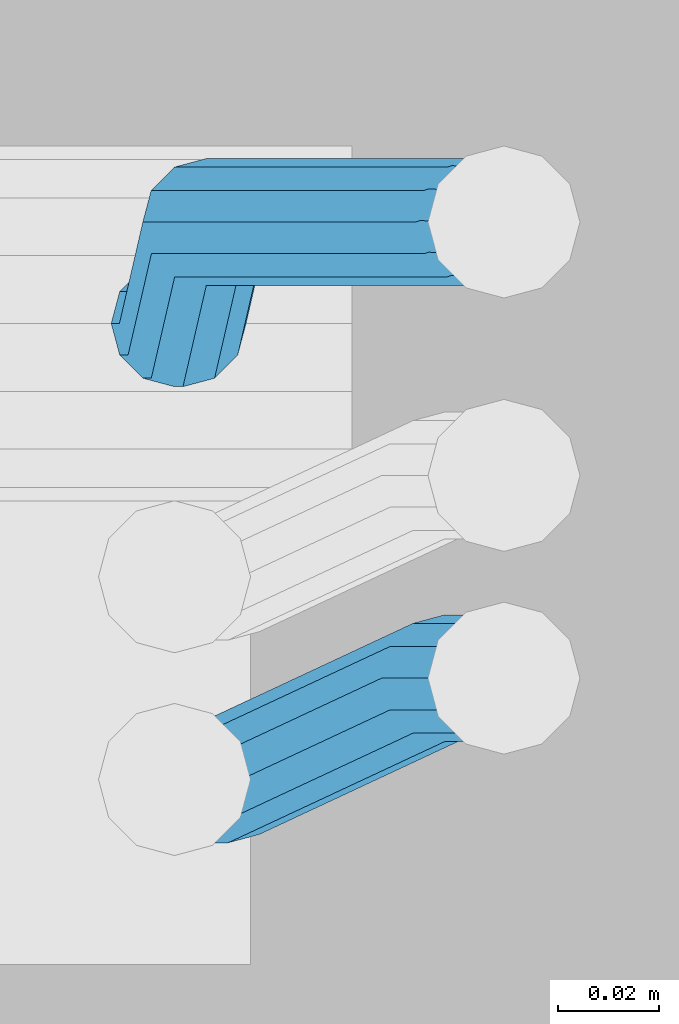
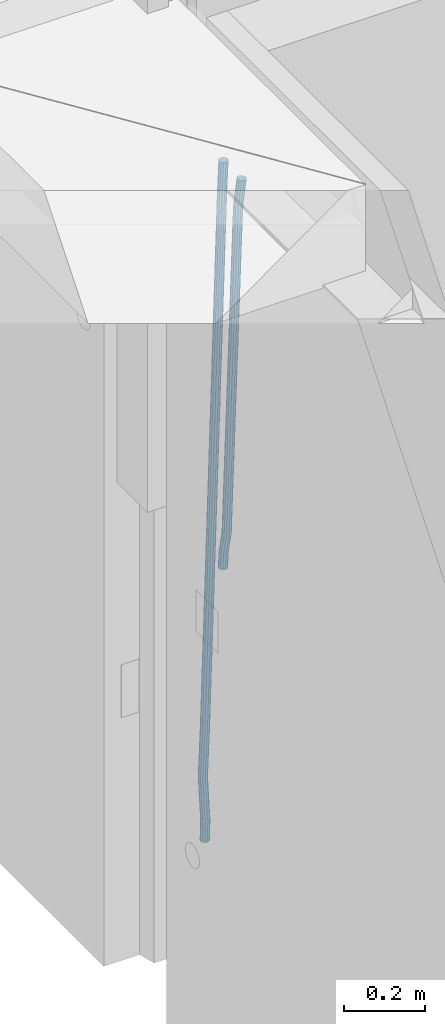
# One storey, part 122 of 349: 2 beams, 1 element without a shape of its own.
"""IFC2X3 building model written with IfcOpenShell, lengths in millimetres."""

from ifc_helpers import new_model, si_unit, frame, origin_with_axes, place, context, subcontext, project, spatial, faceted_brep, material, type_object, element, aggregate, save


model = new_model("IFC2X3")

# Units and contexts
model_context = context("Model", 3, precision=1e-05, world=origin_with_axes())
body_context = subcontext(model_context, "Body", "Model", "MODEL_VIEW")
ifc_project = project(units=[si_unit("LENGTHUNIT", "METRE", prefix="MILLI"), si_unit("AREAUNIT", "SQUARE_METRE"), si_unit("VOLUMEUNIT", "CUBIC_METRE"), si_unit("MASSUNIT", "GRAM", prefix="KILO"), si_unit("TIMEUNIT", "SECOND"), si_unit("PLANEANGLEUNIT", "RADIAN"), si_unit("SOLIDANGLEUNIT", "STERADIAN"), si_unit("THERMODYNAMICTEMPERATUREUNIT", "DEGREE_CELSIUS"), si_unit("LUMINOUSINTENSITYUNIT", "LUMEN")], contexts=[model_context])

# Site, building, storey
site_placement = place(None, origin_with_axes())
site = spatial("IfcSite", under=ifc_project, at=site_placement, CompositionType="ELEMENT")
building_placement = place(site_placement, origin_with_axes())
building = spatial("IfcBuilding", under=site, at=building_placement, CompositionType="ELEMENT")
storey_placement = place(building_placement, origin_with_axes())
storey = spatial("IfcBuildingStorey", under=building, at=storey_placement, Name="4", CompositionType="ELEMENT", Elevation=0.0)

# Assembly, beams
assembly_placement = place(storey_placement, origin_with_axes())
assembly = element("IfcElementAssembly", 1, at=assembly_placement, inside=storey, AssemblyPlace="NOTDEFINED", PredefinedType="REINFORCEMENT_UNIT")
ifc_material = material()
beam_type = type_object("IfcBeamType", Name="D25", PredefinedType="NOTDEFINED")
beam_1_placement = place(assembly_placement, frame((17644.9989431251, 20116.4982803956, 92267.5035525011), z_axis=(0.0, 1.0, 0.0), x_axis=(0.0467115440025518, 0.0, 0.998908420055061)))
beam_1 = element("IfcBeam", 2, at=beam_1_placement, type_object=beam_type, material=ifc_material, Name="JM25", ObjectType="D25", context=body_context, shape_type="Brep", body=[
    faceted_brep([(-7.41420080885291e-08, -12.5, -3.63797880709171e-12), (-6.42030499875546e-08, -10.8253175473074, -6.25000000000364), (48.7743672639481, -10.8253174221936, -6.25), (48.7743672682554, -12.4999998748863, 0.0), (-3.70782800018787e-08, -6.25000000000364, -10.8253175473074), (48.7743672522192, -6.24999987488263, -10.8253175473037), (-1.45519152283669e-11, -3.63797880709171e-12, -12.5), (48.7743672361976, 1.25113729154691e-07, -12.5), (3.70637280866504e-08, 6.25, -10.8253175473074), (48.7743672201614, 6.25000012511737, -10.8253175473037), (6.42030499875546e-08, 10.8253175473001, -6.25000000000364), (48.774367208418, 10.8253176724174, -6.25), (7.41420080885291e-08, 12.4999999999927, 0.0), (48.7743672041252, 12.5000001251174, 0.0), (6.42176019027829e-08, 10.8253175473001, 6.24999999999636), (48.774367208418, 10.8253176724174, 6.25), (3.70928319171071e-08, 6.24999999999636, 10.8253175473037), (48.7743672201614, 6.25000012511737, 10.8253175473037), (1.45519152283669e-11, -3.63797880709171e-12, 12.4999999999964), (48.7743672361976, 1.25113729154691e-07, 12.5), (-3.7049176171422e-08, -6.25000000000364, 10.8253175473001), (48.7743672522192, -6.24999987488263, 10.8253175473037), (-6.41884980723262e-08, -10.8253175473074, 6.25), (48.7743672639481, -10.8253174221936, 6.25), (50.6284132863948, -10.8253174174351, -6.25), (50.7256294211547, -12.4999998698804, 0.0), (50.362813866901, -6.2499998708081, -10.8253175473037), (49.9999983126327, 1.28262399812229e-07, -12.5), (49.6371827583935, 6.25000012732926, -10.8253175473037), (49.3715833388851, 10.8253176739527, -6.25), (49.2743672041252, 12.5000001264016, 0.0), (49.3715833388851, 10.8253176739527, 6.25), (49.6371827583935, 6.25000012732926, 10.8253175473037), (49.9999983126327, 1.28262399812229e-07, 12.5), (50.362813866901, -6.2499998708081, 10.8253175473037), (50.6284132863948, -10.8253174174351, 6.25), (52.4700055286376, -10.6107838149001, -6.25), (52.6637847850943, -12.2742172873113, 0.0), (51.9405907545442, -6.0661990532717, -10.8253175473037), (51.2173967239651, 0.141819180764287, -12.5), (50.494202693415, 6.34983741480755, -10.8253175473037), (49.9647879192926, 10.8944221764359, -6.25), (49.7710086628358, 12.5578556488472, 0.0), (49.9647879192926, 10.8944221764359, 6.25), (50.494202693415, 6.34983741480755, 10.8253175473037), (51.2173967239651, 0.141819180764287, 12.5), (51.9405907545442, -6.0661990532717, 10.8253175473037), (52.4700055286376, -10.6107838149037, 6.25), (100.1682419055, -5.05424733003747, -6.25), (100.362021161956, -6.71768080244692, 0.0), (99.6388271314063, -0.509662568409112, -10.8253175473037), (98.9156331008271, 5.69835566563052, -12.5), (98.192439070277, 11.9063738996665, -10.8253175473037), (97.6630242961546, 16.4509586612985, -6.25), (97.4692450396979, 18.1143921337098, 0.0), (97.6630242961546, 16.4509586612985, 6.25), (98.192439070277, 11.9063738996665, 10.8253175473037), (98.9156331008271, 5.69835566563052, 12.5), (99.6388271314063, -0.509662568409112, 10.8253175473037), (100.1682419055, -5.05424733003747, 6.25), (100.829389846811, -4.97722786481609, -6.25), (100.858662620667, -6.65982528000313, 0.0), (100.613505361369, -0.39611884945225, -10.8253175473037), (100.268855237926, 5.8559973049887, -12.5), (99.8877881987282, 12.1038711239344, -10.8253175473037), (99.5724108491268, 16.6733898631865, -6.25), (99.4072282953421, 18.3401546667665, 0.0), (99.4365010692127, 16.6575572515831, 6.25), (99.6523855546402, 12.0764482362174, 10.8253175473037), (99.9970356780832, 5.82433208178009, 12.5), (100.37810271731, -0.423541737165579, 10.8253175473037), (100.693480066882, -4.99306047642312, 6.25), (101.494850382805, -4.9772278650471, -6.23547852116099), (101.358543616545, -6.65982528017412, 0.0109082521194068), (101.594541309358, -0.396118849792401, -10.8039096771354), (101.63090429295, 5.85599730451395, -12.4702777768798), (101.594195901474, 12.1038711233377, -10.7880808337759), (101.49425211882, 16.6733898625134, -6.2080621602363), (101.357852800793, 18.340154666088, 0.0425659388420172), (101.221546034547, 16.6575572509591, 6.28895271212241), (101.121855107995, 12.0764482357044, 10.8573838680968), (101.085492124403, 5.82433208139992, 12.5237519678412), (101.122200515863, -0.423541737425694, 10.8415550247373), (101.222144298532, -4.99306047660866, 6.26153635119772), (1016.15234243186, -4.97722818425427, 13.7239010304511), (1016.01603566563, -6.65982559938311, 19.9702878037351), (1016.25203335841, -0.396119168995938, 9.15546987447669), (1016.28839634202, 5.85599698530859, 7.48910177473226), (1016.25168795056, 12.1038708041378, 9.17129871783618), (1016.15174416787, 16.6733895433135, 13.7513173913758), (1016.01534484986, 18.3401543468826, 20.0019454904541), (1015.8790380836, 16.6575569317556, 26.2483322637381), (1015.77934715705, 12.0764479165045, 30.8167634197125), (1015.74298417347, 5.82433176219456, 32.4831315194569), (1015.77969256493, -0.423542056632868, 30.8009345763494), (1015.8796363476, -4.99306079580856, 26.2209159028134), (1016.72024271244, -4.97722818445254, 13.7362935788587), (1016.65208128402, -6.65982559960139, 19.984167399125), (1016.77009392806, -0.396119169179656, 9.16677483576495), (1016.7882773379, 5.85599698513579, 7.50001002685531), (1016.76992071191, 12.1038708039559, 9.18260743664359), (1016.71994269331, 16.6733895431171, 13.7637164479929), (1016.65173485172, 18.3401543466607, 20.015832600875), (1016.58357342328, 16.65755693151, 26.2637064211413), (1016.53372220766, 12.0764479162353, 30.833225164235), (1016.51553879784, 5.82433176192717, 32.4999899731447), (1016.53389542381, -0.423542056894803, 30.8173925633564), (1016.58387344243, -4.99306079605594, 26.2362835520071), (1017.28827819017, -4.97722813975997, 13.7362935788587), (1017.28827832255, -6.6598255495519, 19.984167399125), (1017.28827782976, -0.396119128414284, 9.16677483576495), (1017.28827733788, 5.85599702447144, 7.50001002685531), (1017.28827684635, 12.103870844734, 9.18260743664359), (1017.28827648686, 16.6733895878278, 13.7637164479929), (1017.28827635571, 18.3401543967448, 20.015832600875), (1017.28827648809, 16.657556986951, 26.2637064211413), (1017.2882768485, 12.0764479756035, 30.833225164235), (1017.28827734038, 5.8243318227178, 32.4999899731447), (1017.28827783192, -0.423541997544817, 30.8173925633564), (1017.28827819142, -4.99306074063679, 26.2362835520071), (1065.6667756622, -4.97722433367016, 13.7362935788587), (1065.66677579457, -6.65982174345845, 19.984167399125), (1065.6667753018, -0.3961153223172, 9.16677483576495), (1065.66677480991, 5.85600083056488, 7.50001002685531), (1065.66677431838, 12.1038746508275, 9.18260743664359), (1065.66677395887, 16.6733933939249, 13.7637164479929), (1065.66677382775, 18.3401582028346, 20.015832600875), (1065.66677396011, 16.6575607930445, 26.2637064211413), (1065.66677432053, 12.0764517816933, 30.833225164235), (1065.6667748124, 5.82433562881488, 32.4999899731447), (1065.66677530395, -0.423538191451371, 30.8173925633564), (1065.66677566344, -4.99305693454517, 26.2362835520071), (1067.07165110651, -4.97722422314291, 13.7362935788587), (1067.13694763639, -6.65982162779255, 19.984167399125), (1066.89387208481, -0.396115225779795, 9.16677483576495), (1066.6512463166, 5.85600090801745, 7.50001002685531), (1066.40878518049, 12.1038747092061, 9.18260743664359), (1066.23145594214, 16.6733934383519, 13.7637164479929), (1066.16677382775, 18.340158242172, 20.015832600875), (1066.23207035761, 16.6575608375188, 26.2637064211413), (1066.40984937931, 12.0764518401556, 30.833225164235), (1066.65247514757, 5.82433570636204, 32.4999899731447), (1066.89493628364, -0.423538094826654, 30.8173925633564), (1067.07226552199, -4.99305682397062, 26.2362835520071), (1068.47230333716, -4.86837412698696, 13.736334784764), (1068.60269804588, -6.54588751704068, 19.9842150143704), (1068.11728165975, -0.301059828409052, 9.16679859123906), (1067.63276078545, 5.93224720081525, 7.50000996663584), (1067.14856769117, 12.161337376032, 9.18258357686864), (1066.79444152558, 16.7171310152116, 13.7636751818718), (1066.66527010873, 18.3789068918468, 20.0157849856296), (1066.79566481744, 16.7013935018003, 26.263665215236), (1067.15068649485, 12.134079203217, 30.8332014087609), (1067.63520736917, 5.90077217399266, 32.4999900333642), (1068.11940046342, -0.328318001224034, 30.8174164231314), (1068.47352662902, -4.88411164040008, 26.2363248181282), (1142.62319484423, 0.89544508106701, 13.736334784764), (1142.75358955294, -0.782068308983071, 19.9842150143704), (1142.26817316683, 5.4627593796431, 9.16679859123906), (1141.78365229251, 11.6960664088729, 7.50000996663584), (1141.29945919824, 17.9251565840896, 9.18258357686864), (1140.94533303265, 22.4809502232638, 13.7636751818718), (1140.81616161579, 24.1427260999008, 20.0157849856296), (1140.94655632452, 22.4652127098525, 26.263665215236), (1141.30157800192, 17.8978984112746, 30.8332014087609), (1141.78609887623, 11.6645913820466, 32.4999900333642), (1142.27029197049, 5.43550120682994, 30.8174164231314), (1142.6244181361, 0.879707567652076, 26.2363248181282)], [[[0, 1, 2, 3]], [[1, 4, 5, 2]], [[4, 6, 7, 5]], [[6, 8, 9, 7]], [[8, 10, 11, 9]], [[10, 12, 13, 11]], [[12, 14, 15, 13]], [[14, 16, 17, 15]], [[16, 18, 19, 17]], [[18, 20, 21, 19]], [[20, 22, 23, 21]], [[22, 0, 3, 23]], [[22, 20, 18, 16, 14, 12, 10, 8, 6, 4, 1, 0]], [[3, 2, 24, 25]], [[2, 5, 26, 24]], [[5, 7, 27, 26]], [[7, 9, 28, 27]], [[9, 11, 29, 28]], [[11, 13, 30, 29]], [[13, 15, 31, 30]], [[15, 17, 32, 31]], [[17, 19, 33, 32]], [[19, 21, 34, 33]], [[21, 23, 35, 34]], [[23, 3, 25, 35]], [[25, 24, 36, 37]], [[24, 26, 38, 36]], [[26, 27, 39, 38]], [[27, 28, 40, 39]], [[28, 29, 41, 40]], [[29, 30, 42, 41]], [[30, 31, 43, 42]], [[31, 32, 44, 43]], [[32, 33, 45, 44]], [[33, 34, 46, 45]], [[34, 35, 47, 46]], [[35, 25, 37, 47]], [[37, 36, 48, 49]], [[36, 38, 50, 48]], [[38, 39, 51, 50]], [[39, 40, 52, 51]], [[40, 41, 53, 52]], [[41, 42, 54, 53]], [[42, 43, 55, 54]], [[43, 44, 56, 55]], [[44, 45, 57, 56]], [[45, 46, 58, 57]], [[46, 47, 59, 58]], [[47, 37, 49, 59]], [[49, 48, 60, 61]], [[48, 50, 62, 60]], [[50, 51, 63, 62]], [[51, 52, 64, 63]], [[52, 53, 65, 64]], [[53, 54, 66, 65]], [[54, 55, 67, 66]], [[55, 56, 68, 67]], [[56, 57, 69, 68]], [[57, 58, 70, 69]], [[58, 59, 71, 70]], [[59, 49, 61, 71]], [[61, 60, 72, 73]], [[60, 62, 74, 72]], [[62, 63, 75, 74]], [[63, 64, 76, 75]], [[64, 65, 77, 76]], [[65, 66, 78, 77]], [[66, 67, 79, 78]], [[67, 68, 80, 79]], [[68, 69, 81, 80]], [[69, 70, 82, 81]], [[70, 71, 83, 82]], [[71, 61, 73, 83]], [[73, 72, 84, 85]], [[72, 74, 86, 84]], [[74, 75, 87, 86]], [[75, 76, 88, 87]], [[76, 77, 89, 88]], [[77, 78, 90, 89]], [[78, 79, 91, 90]], [[79, 80, 92, 91]], [[80, 81, 93, 92]], [[81, 82, 94, 93]], [[82, 83, 95, 94]], [[83, 73, 85, 95]], [[85, 84, 96, 97]], [[84, 86, 98, 96]], [[86, 87, 99, 98]], [[87, 88, 100, 99]], [[88, 89, 101, 100]], [[89, 90, 102, 101]], [[90, 91, 103, 102]], [[91, 92, 104, 103]], [[92, 93, 105, 104]], [[93, 94, 106, 105]], [[94, 95, 107, 106]], [[95, 85, 97, 107]], [[97, 96, 108, 109]], [[96, 98, 110, 108]], [[98, 99, 111, 110]], [[99, 100, 112, 111]], [[100, 101, 113, 112]], [[101, 102, 114, 113]], [[102, 103, 115, 114]], [[103, 104, 116, 115]], [[104, 105, 117, 116]], [[105, 106, 118, 117]], [[106, 107, 119, 118]], [[107, 97, 109, 119]], [[109, 108, 120, 121]], [[108, 110, 122, 120]], [[110, 111, 123, 122]], [[111, 112, 124, 123]], [[112, 113, 125, 124]], [[113, 114, 126, 125]], [[114, 115, 127, 126]], [[115, 116, 128, 127]], [[116, 117, 129, 128]], [[117, 118, 130, 129]], [[118, 119, 131, 130]], [[119, 109, 121, 131]], [[121, 120, 132, 133]], [[120, 122, 134, 132]], [[122, 123, 135, 134]], [[123, 124, 136, 135]], [[124, 125, 137, 136]], [[125, 126, 138, 137]], [[126, 127, 139, 138]], [[127, 128, 140, 139]], [[128, 129, 141, 140]], [[129, 130, 142, 141]], [[130, 131, 143, 142]], [[131, 121, 133, 143]], [[133, 132, 144, 145]], [[132, 134, 146, 144]], [[134, 135, 147, 146]], [[135, 136, 148, 147]], [[136, 137, 149, 148]], [[137, 138, 150, 149]], [[138, 139, 151, 150]], [[139, 140, 152, 151]], [[140, 141, 153, 152]], [[141, 142, 154, 153]], [[142, 143, 155, 154]], [[143, 133, 145, 155]], [[145, 144, 156, 157]], [[144, 146, 158, 156]], [[146, 147, 159, 158]], [[147, 148, 160, 159]], [[148, 149, 161, 160]], [[149, 150, 162, 161]], [[150, 151, 163, 162]], [[151, 152, 164, 163]], [[152, 153, 165, 164]], [[153, 154, 166, 165]], [[154, 155, 167, 166]], [[155, 145, 157, 167]], [[158, 159, 160, 161, 162, 163, 164, 165, 166, 167, 157, 156]]]),
])
beam_2_placement = place(assembly_placement, frame((17645.0, 20206.4982799665, 91390.0), z_axis=(0.999642804629538, 0.000205762999925497, -0.0267249099901003), x_axis=(0.0267249109941254, -4.30000210532798e-08, 0.999642825779465)))
beam_2 = element("IfcBeam", 3, at=beam_2_placement, type_object=beam_type, material=ifc_material, Name="JM25", ObjectType="D25", context=body_context, shape_type="Brep", body=[
    faceted_brep([(-7.41420080885291e-08, -12.5, -3.63797880709171e-12), (-6.42030499875546e-08, -10.8253175473074, -6.25000000000364), (59.4220778053423, -10.8253175324608, -6.25000005319089), (59.4220778086747, -12.4999999851534, -5.3194526117295e-08), (-3.70782800018787e-08, -6.25000000000364, -10.8253175473074), (59.4220778020681, -6.24999998515341, -10.8253176004946), (-1.45519152283669e-11, -3.63797880709171e-12, -12.5), (59.4220777997252, 1.48465915117413e-08, -12.5000000531927), (3.70637280866504e-08, 6.25, -10.8253175473074), (59.422077798954, 6.25000001485023, -10.8253176004982), (6.42030499875546e-08, 10.8253175473001, -6.25000000000364), (59.4220777999435, 10.8253175621539, -6.25000005319089), (7.41420080885291e-08, 12.4999999999927, 0.0), (59.4220778024173, 12.5000000148466, -5.31908881384879e-08), (6.42176019027829e-08, 10.8253175473001, 6.24999999999636), (59.4220778057497, 10.8253175621576, 6.24999994680911), (3.70928319171071e-08, 6.24999999999636, 10.8253175473037), (59.4220778090239, 6.25000001485023, 10.8253174941128), (1.45519152283669e-11, -3.63797880709171e-12, 12.4999999999964), (59.4220778113668, 1.48465915117413e-08, 12.4999999468128), (-3.7049176171422e-08, -6.25000000000364, 10.8253175473001), (59.4220778121526, -6.24999998515705, 10.8253174941183), (-6.41884980723262e-08, -10.8253175473074, 6.25), (59.422077811163, -10.8253175324571, 6.24999994680547), (60.1059015733626, -10.8253175322861, -6.25000005380571), (59.9220778086747, -12.4999999850261, -5.36383595317602e-08), (60.5270973313018, -6.24999998487692, -10.8253176014878), (61.0728060192778, 1.52613210957497e-08, -12.5000000546715), (61.5968054350378, 6.25000001539229, -10.8253176024446), (61.9586903583258, 10.825317562787, -6.25000005546281), (62.0614940161613, 12.5000000155051, -5.55555743630975e-08), (61.8776702514588, 10.8253175627651, 6.24999994460995), (61.4564744935342, 6.25000001535955, 10.8253174922938), (60.9107658055436, 1.52213033288717e-08, 12.4999999454776), (60.3867663897981, -6.2499999849133, 10.8253174932506), (60.0248814664956, -10.825317532308, 6.24999994626887), (60.7797257564671, -10.9415004936782, -6.24120031120765), (60.4147662867617, -12.5849509379113, 0.00643416450657242), (61.6159581115353, -6.43774490879878, -10.8110977280703), (62.6993955677171, -0.280461855141766, -12.4787577637399), (63.739731933616, 5.88050964549984, -10.7973322583985), (64.4582099200925, 10.3943422549237, -6.21735781835014), (64.6623139309086, 12.0515581706859, 0.03396510384664), (64.2973544612178, 10.4081077264564, 6.28159957956086), (63.461122106135, 5.90435214157333, 10.8514969964235), (62.3776846499532, -0.252930912083684, 12.5191570320894), (61.3373482840689, -6.41390241272165, 10.8377315267553), (60.6188702975924, -10.9277350221564, 6.25775708670699), (173.678050556482, -30.407797550004, -4.76681541592006), (173.313091086762, -32.0512479942336, 1.4808190597978), (174.514282911536, -25.9040419651246, -9.33671283278272), (175.597720367718, -19.7467589114676, -11.0043728684504), (176.638056733602, -13.585787410826, -9.32294736311087), (177.356534720093, -9.0719548013949, -4.74297292306073), (177.560638730924, -7.41473888563996, 1.50834999913423), (177.195679261218, -9.05818932986585, 7.75598447485027), (176.35944690615, -13.5619449147489, 12.3258818917166), (175.276009449968, -19.7192279684059, 13.9935419273806), (174.235673084069, -25.8801994690475, 12.3121164220465), (173.517195097593, -30.3940320784823, 7.73214198199094), (176.138237106381, -30.8319909317906, -4.73468684452382), (175.913853754129, -32.499679968274, 1.51478347157899), (176.589132212815, -26.2617942428296, -9.30961653639861), (177.145722093832, -20.0136704134529, -10.98415688768), (177.658868940271, -13.7617991779516, -9.30961616354944), (177.991075469021, -9.18136438506554, -4.73468619872801), (178.053327209011, -7.49968983852159, 1.5147842172828), (177.828943856759, -9.16737887500858, 7.76425453338925), (177.37804875031, -13.7375755639696, 12.3391842252604), (176.821458869294, -19.9856993933463, 14.0137245765418), (176.308312022869, -26.237570628844, 12.3391838524112), (175.976105494119, -30.8180054217337, 7.76425388758798), (178.634722048839, -30.8318743800774, -4.70223538057326), (178.552989161486, -32.4996730848652, 1.54907076560085), (178.694593853957, -26.2615981169292, -9.28219734144659), (178.71656197503, -20.0134461293128, -10.9636180082289), (178.694740071747, -13.7616056964944, -9.29596207112627), (178.634975305482, -9.18125241366579, -4.72607659172718), (178.553281597095, -7.49968824400275, 1.52154130624513), (178.471548709742, -9.16748694879061, 7.7728474524265), (178.411676904623, -13.7377632119424, 12.3528094132944), (178.389708783536, -19.9859151995588, 14.0342300800785), (178.411530686833, -26.23775563237, 12.3665741429741), (178.471295453099, -30.8181089152022, 7.79668866358043), (319.488626215083, -30.8314939674237, -2.86053540860667), (319.406893327759, -32.499292672208, 3.39077073757289), (319.548498020216, -26.261217704272, -7.44049736947818), (319.570466141289, -20.0130657166519, -9.12191803626411), (319.548644237992, -13.7612252838408, -7.45426209915786), (319.488879471741, -9.18087200101581, -2.88437661976423), (319.407185763353, -7.4993078313455, 3.36324127821172), (319.325452876015, -9.167106536137, 9.61454742438946), (319.265581070882, -13.7373827992851, 14.1945093852592), (319.243612949809, -19.9855347868979, 15.8759300520433), (319.265434853078, -26.2373752197163, 14.2082741149388), (319.325199619343, -30.8177285025449, 9.63838863554338), (320.017443228702, -30.8314925392151, -2.85362099409576), (319.964532372032, -32.4992911661575, 3.39806200733256), (320.056202037245, -26.2612163330814, -7.43385901266629), (320.070423406214, -20.013064366387, -9.11538097016819), (320.056296731302, -13.7612239127957, -7.44762441603234), (320.01760724363, -9.18087057304729, -2.87746337211138), (319.964721760145, -7.4993063255788, 3.37053120060227), (319.91181090349, -9.16710495252482, 9.62221420203059), (319.873052094961, -13.7373811586476, 14.2024522205975), (319.858830725978, -19.9855331253457, 15.8839741781048), (319.87295740089, -26.2373735789442, 14.2162176239653), (319.911646888577, -30.8177269186926, 9.64605658004257), (320.546301518712, -30.8314921215424, -2.85158332608989), (320.522214942423, -32.4992907257256, 3.40021073403295), (320.563945682734, -26.2612159320888, -7.431902698474), (320.570419694937, -20.0130639715098, -9.1134545062032), (320.563988849026, -13.7612235118395, -7.44566830037184), (320.546376284925, -9.1808701554437, -2.87542604797454), (320.522301275021, -7.49930588522329, 3.37267953023547), (320.498214698731, -9.16710448940648, 9.62447359036014), (320.480570534695, -13.7373806788601, 14.2047929627461), (320.474096522506, -19.9855326394354, 15.8863447704753), (320.480527368418, -26.2373730991094, 14.2185585646439), (320.498139932504, -30.8177264555052, 9.64831631225024), (1894.35323904471, -30.8302491939103, 3.21222639639745), (1894.32915246842, -32.4980477980898, 9.46402045652394), (1894.37088320871, -26.2599730044531, -1.36809297598302), (1894.37735722095, -20.0118210438777, -3.04964478371585), (1894.37092637502, -13.7599805842037, -1.38185857788449), (1894.35331381093, -9.1796272278043, 3.18838367451281), (1894.32923880102, -7.4980629575839, 9.43648925272464), (1894.30515222471, -9.16586156176709, 15.6882833128511), (1894.2875080607, -13.7361377512207, 20.2686026852371), (1894.28103404849, -19.9842897117996, 21.9501544929644), (1894.2874648944, -26.2361301714736, 20.2823682871331), (1894.30507745848, -30.8164835278658, 15.7121260347358), (1894.91223858956, -30.8302487524343, 3.21438019734705), (1894.84772318714, -32.4980473885444, 9.46601848696628), (1894.98133310449, -26.2599725223481, -1.36574093906893), (1895.03649291246, -20.0118205233157, -3.04710516254454), (1895.06293798747, -13.7599800376811, -1.37919228721876), (1895.05358239301, -9.17962667476604, 3.19108177892304), (1895.01093295308, -7.49806241920669, 9.43911579066662), (1894.94641755069, -9.16586105532406, 15.6907540802767), (1894.87732303573, -13.7361372854102, 20.2708752166945), (1894.82216322777, -19.984289284439, 21.9522394401702), (1894.79571815276, -26.2361297700772, 20.284326564848), (1894.80507374721, -30.8164831329887, 15.7140524987026), (1895.47114527243, -30.837537004496, 3.22181869265842), (1895.36620776, -32.5048085284143, 9.47291900396158), (1895.59168159126, -26.267931585553, -1.35761780421126), (1895.69551910722, -20.0204143533228, -3.03833417552232), (1895.75483464175, -13.7690025048832, -1.36998382688762), (1895.75373464527, -9.18875679657504, 3.20040011310266), (1895.69251386097, -7.50695036707475, 9.44818695861068), (1895.58757634854, -9.17422189099307, 15.699287269912), (1895.4670400297, -13.7438273099324, 20.2787237667835), (1895.36320251375, -19.9913445421626, 21.9594401380946), (1895.30388697921, -26.2427563905985, 20.2910897894599), (1895.30498697569, -30.823002098914, 15.720705849466), (1917.25744196717, -31.1216345590001, 3.51177275974987), (1917.15250445475, -32.788906082922, 9.7628730710494), (1917.37797828601, -26.5520291400608, -1.0676637371198), (1917.48181580196, -20.3045119078306, -2.7483801084345), (1917.5411313365, -14.0531000593946, -1.08002975979252), (1917.54003134, -9.47285435107915, 3.49035418019412), (1917.47881055571, -7.7910479215825, 9.73814102570577), (1917.37387304328, -9.45831944550082, 15.9892413370071), (1917.25333672446, -14.0279248644365, 20.5686778338786), (1917.14949920849, -20.2754420966667, 22.2493942051933), (1917.09018367396, -26.5268539451099, 20.5810438565477), (1917.09128367042, -31.1070996534218, 16.0106599165647), (1917.94316974688, -31.1305765828838, 3.52089911846269), (1917.85264237775, -32.7980360178735, 9.77219121452072), (1918.02633208608, -26.5604837999635, -1.05903478912296), (1918.0798461137, -20.3123103396429, -2.7404209163069), (1918.08937278928, -14.0602492347753, -1.07273320814602), (1918.05235944779, -9.47953520944429, 3.49717276072806), (1917.9787237842, -7.79756688750422, 9.74479437647096), (1917.88819641506, -9.46502632249758, 15.9960864725308), (1917.80503407588, -14.0351191054142, 20.5760203801128), (1917.75152004823, -20.2832925657385, 22.257406507304), (1917.74199337266, -26.5353536706025, 20.5897187991395), (1917.77900671415, -31.1160676959298, 16.0198128302654), (1918.62895550129, -31.1285475281402, 3.52982218347461), (1918.55283939735, -32.795947999115, 9.78130547352521), (1918.67474087057, -26.5585779185749, -1.05060823136955), (1918.67792735249, -20.3105588367471, -2.73266314035027), (1918.63766113177, -14.0586419499232, -1.06563728897891), (1918.56473150974, -9.47802333907384, 3.50379109209644), (1918.47867991975, -7.79607606181162, 9.75124735830832), (1918.40256381579, -9.46347653279008, 16.0027306483644), (1918.35677844651, -14.0334461423481, 20.5831610632049), (1918.35359196461, -20.2814652241759, 22.2652159721838), (1918.39385818531, -26.5333821109998, 20.5981901208143), (1918.46678780734, -31.1140007218564, 16.0287617397316), (2018.62971518922, -30.8303462840922, 4.82693655916046), (2018.5535990853, -32.4977467550671, 11.0784198492183), (2018.67550055851, -26.2603766745233, 0.246506144323575), (2018.67868704045, -20.0123575926991, -1.43554876465714), (2018.63842081973, -13.7604407058789, 0.231477086710584), (2018.5654911977, -9.17982209502588, 4.80090546778956), (2018.47943960771, -7.49787481776366, 11.0483617339996), (2018.40332350375, -9.16527528874212, 17.2998450240593), (2018.35753813446, -13.7352448983038, 21.880275438898), (2018.35435165254, -19.9832639801316, 23.5623303478787), (2018.39461787326, -26.2351808669555, 21.8953044965092), (2018.46754749528, -30.8157994778048, 17.3258761154248)], [[[0, 1, 2, 3]], [[1, 4, 5, 2]], [[4, 6, 7, 5]], [[6, 8, 9, 7]], [[8, 10, 11, 9]], [[10, 12, 13, 11]], [[12, 14, 15, 13]], [[14, 16, 17, 15]], [[16, 18, 19, 17]], [[18, 20, 21, 19]], [[20, 22, 23, 21]], [[22, 0, 3, 23]], [[22, 20, 18, 16, 14, 12, 10, 8, 6, 4, 1, 0]], [[3, 2, 24, 25]], [[2, 5, 26, 24]], [[5, 7, 27, 26]], [[7, 9, 28, 27]], [[9, 11, 29, 28]], [[11, 13, 30, 29]], [[13, 15, 31, 30]], [[15, 17, 32, 31]], [[17, 19, 33, 32]], [[19, 21, 34, 33]], [[21, 23, 35, 34]], [[23, 3, 25, 35]], [[25, 24, 36, 37]], [[24, 26, 38, 36]], [[26, 27, 39, 38]], [[27, 28, 40, 39]], [[28, 29, 41, 40]], [[29, 30, 42, 41]], [[30, 31, 43, 42]], [[31, 32, 44, 43]], [[32, 33, 45, 44]], [[33, 34, 46, 45]], [[34, 35, 47, 46]], [[35, 25, 37, 47]], [[37, 36, 48, 49]], [[36, 38, 50, 48]], [[38, 39, 51, 50]], [[39, 40, 52, 51]], [[40, 41, 53, 52]], [[41, 42, 54, 53]], [[42, 43, 55, 54]], [[43, 44, 56, 55]], [[44, 45, 57, 56]], [[45, 46, 58, 57]], [[46, 47, 59, 58]], [[47, 37, 49, 59]], [[49, 48, 60, 61]], [[48, 50, 62, 60]], [[50, 51, 63, 62]], [[51, 52, 64, 63]], [[52, 53, 65, 64]], [[53, 54, 66, 65]], [[54, 55, 67, 66]], [[55, 56, 68, 67]], [[56, 57, 69, 68]], [[57, 58, 70, 69]], [[58, 59, 71, 70]], [[59, 49, 61, 71]], [[61, 60, 72, 73]], [[60, 62, 74, 72]], [[62, 63, 75, 74]], [[63, 64, 76, 75]], [[64, 65, 77, 76]], [[65, 66, 78, 77]], [[66, 67, 79, 78]], [[67, 68, 80, 79]], [[68, 69, 81, 80]], [[69, 70, 82, 81]], [[70, 71, 83, 82]], [[71, 61, 73, 83]], [[73, 72, 84, 85]], [[72, 74, 86, 84]], [[74, 75, 87, 86]], [[75, 76, 88, 87]], [[76, 77, 89, 88]], [[77, 78, 90, 89]], [[78, 79, 91, 90]], [[79, 80, 92, 91]], [[80, 81, 93, 92]], [[81, 82, 94, 93]], [[82, 83, 95, 94]], [[83, 73, 85, 95]], [[85, 84, 96, 97]], [[84, 86, 98, 96]], [[86, 87, 99, 98]], [[87, 88, 100, 99]], [[88, 89, 101, 100]], [[89, 90, 102, 101]], [[90, 91, 103, 102]], [[91, 92, 104, 103]], [[92, 93, 105, 104]], [[93, 94, 106, 105]], [[94, 95, 107, 106]], [[95, 85, 97, 107]], [[97, 96, 108, 109]], [[96, 98, 110, 108]], [[98, 99, 111, 110]], [[99, 100, 112, 111]], [[100, 101, 113, 112]], [[101, 102, 114, 113]], [[102, 103, 115, 114]], [[103, 104, 116, 115]], [[104, 105, 117, 116]], [[105, 106, 118, 117]], [[106, 107, 119, 118]], [[107, 97, 109, 119]], [[109, 108, 120, 121]], [[108, 110, 122, 120]], [[110, 111, 123, 122]], [[111, 112, 124, 123]], [[112, 113, 125, 124]], [[113, 114, 126, 125]], [[114, 115, 127, 126]], [[115, 116, 128, 127]], [[116, 117, 129, 128]], [[117, 118, 130, 129]], [[118, 119, 131, 130]], [[119, 109, 121, 131]], [[121, 120, 132, 133]], [[120, 122, 134, 132]], [[122, 123, 135, 134]], [[123, 124, 136, 135]], [[124, 125, 137, 136]], [[125, 126, 138, 137]], [[126, 127, 139, 138]], [[127, 128, 140, 139]], [[128, 129, 141, 140]], [[129, 130, 142, 141]], [[130, 131, 143, 142]], [[131, 121, 133, 143]], [[133, 132, 144, 145]], [[132, 134, 146, 144]], [[134, 135, 147, 146]], [[135, 136, 148, 147]], [[136, 137, 149, 148]], [[137, 138, 150, 149]], [[138, 139, 151, 150]], [[139, 140, 152, 151]], [[140, 141, 153, 152]], [[141, 142, 154, 153]], [[142, 143, 155, 154]], [[143, 133, 145, 155]], [[145, 144, 156, 157]], [[144, 146, 158, 156]], [[146, 147, 159, 158]], [[147, 148, 160, 159]], [[148, 149, 161, 160]], [[149, 150, 162, 161]], [[150, 151, 163, 162]], [[151, 152, 164, 163]], [[152, 153, 165, 164]], [[153, 154, 166, 165]], [[154, 155, 167, 166]], [[155, 145, 157, 167]], [[157, 156, 168, 169]], [[156, 158, 170, 168]], [[158, 159, 171, 170]], [[159, 160, 172, 171]], [[160, 161, 173, 172]], [[161, 162, 174, 173]], [[162, 163, 175, 174]], [[163, 164, 176, 175]], [[164, 165, 177, 176]], [[165, 166, 178, 177]], [[166, 167, 179, 178]], [[167, 157, 169, 179]], [[169, 168, 180, 181]], [[168, 170, 182, 180]], [[170, 171, 183, 182]], [[171, 172, 184, 183]], [[172, 173, 185, 184]], [[173, 174, 186, 185]], [[174, 175, 187, 186]], [[175, 176, 188, 187]], [[176, 177, 189, 188]], [[177, 178, 190, 189]], [[178, 179, 191, 190]], [[179, 169, 181, 191]], [[181, 180, 192, 193]], [[180, 182, 194, 192]], [[182, 183, 195, 194]], [[183, 184, 196, 195]], [[184, 185, 197, 196]], [[185, 186, 198, 197]], [[186, 187, 199, 198]], [[187, 188, 200, 199]], [[188, 189, 201, 200]], [[189, 190, 202, 201]], [[190, 191, 203, 202]], [[191, 181, 193, 203]], [[194, 195, 196, 197, 198, 199, 200, 201, 202, 203, 193, 192]]]),
])
aggregate(assembly, [beam_1, beam_2])

save(model, "model.ifc")
